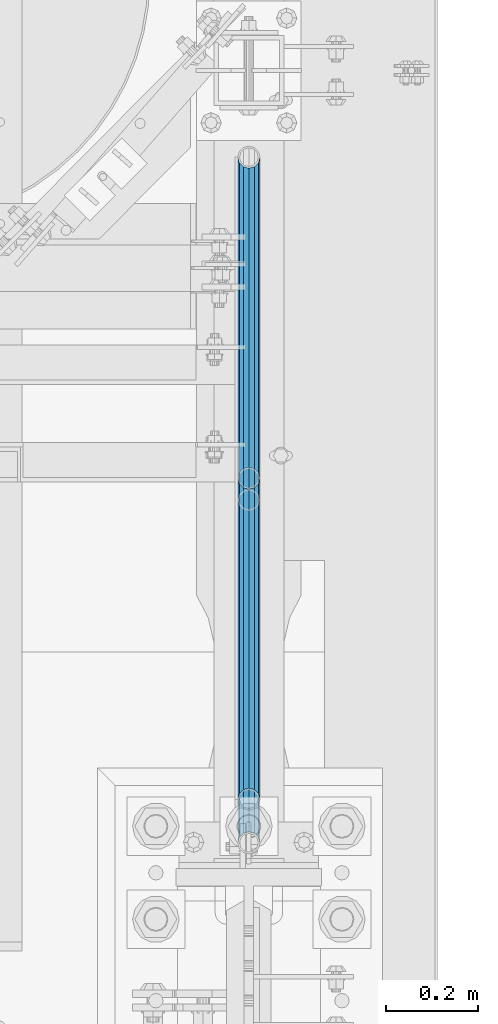
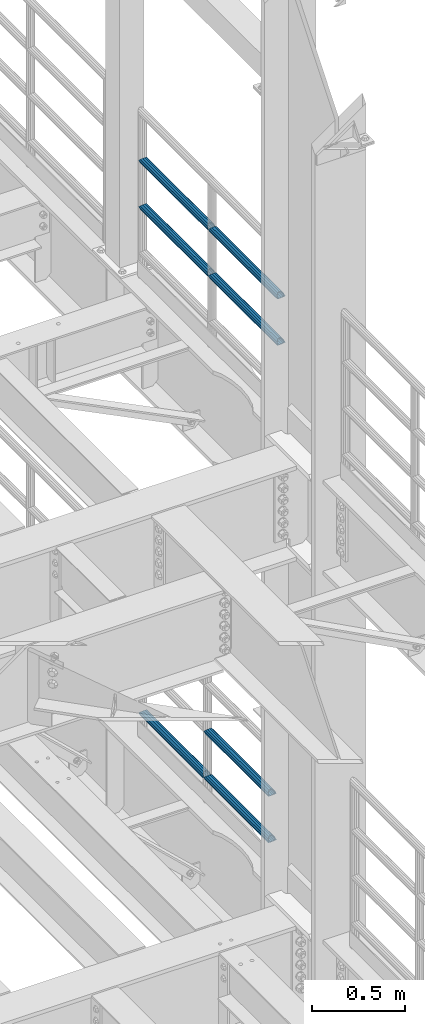
# One storey, part 1276 of 1876: 7 beams, 2 elements without a shape of their own.
"""IFC2X3 building model written with IfcOpenShell, lengths in millimetres."""

import ifcopenshell
import ifcopenshell.guid

model = None  # the IFC model being written
_history = None  # IfcOwnerHistory: only IFC2X3 demands one
_inside = {}  # id of a spatial element -> (the spatial element, [elements in it])
_under = {}  # id of a project, library or spatial element -> (it, [spatial elements below it])
_declared = {}  # id of a project -> (the project, [libraries it declares])
_typed = {}  # id of a type object -> (the type object, [elements of that type])
_made_of = {}  # id of a material, layer set ... -> (it, [elements and type objects made of it])


def new_model(schema):
    """Start an empty IFC model of exactly this schema.

    Asked for "IFC4X3", IfcOpenShell would pick the latest addendum, in which some entities
    have other attributes; the version numbers below select the first issue.
    IFC2X3 requires an IfcOwnerHistory on every rooted entity: one is made here for all.
    """
    global model, _history
    if schema == "IFC4X3":
        model = ifcopenshell.file(schema_version=(4, 3, 0, 0))
    else:
        model = ifcopenshell.file(schema=schema)
    _inside.clear()
    _under.clear()
    _declared.clear()
    _typed.clear()
    _made_of.clear()
    _history = None
    if model.schema == "IFC2X3":
        org = make("IfcOrganization", Name="unknown")
        user = make(
            "IfcPersonAndOrganization",
            ThePerson=make("IfcPerson", FamilyName="unknown"),
            TheOrganization=org,
        )
        app = make(
            "IfcApplication",
            ApplicationDeveloper=org,
            Version="unknown",
            ApplicationFullName="unknown",
            ApplicationIdentifier="unknown",
        )
        _history = make(
            "IfcOwnerHistory",
            OwningUser=user,
            OwningApplication=app,
            ChangeAction="ADDED",
            CreationDate=0,
        )
    return model


def make(cls, **values):
    """One entity of the class cls with the attributes given. An attribute that is None is left unset."""
    return model.create_entity(
        cls, **{name: value for name, value in values.items() if value is not None}
    )


def rooted(cls, **values):
    """An entity with a GlobalId (a new one), such as an element, a storey or a relation."""
    return make(cls, GlobalId=ifcopenshell.guid.new(), OwnerHistory=_history, **values)


def si_unit(unit_type, name, prefix=None):
    """IfcSIUnit, for example si_unit("LENGTHUNIT", "METRE", prefix="MILLI")."""
    return make("IfcSIUnit", UnitType=unit_type, Prefix=prefix, Name=name)


def assignment(units):
    """IfcUnitAssignment: the units of a project."""
    return None if units is None else make("IfcUnitAssignment", Units=units)


def point(xyz):
    """IfcCartesianPoint."""
    return None if xyz is None else make("IfcCartesianPoint", Coordinates=xyz)


def direction(xyz):
    """IfcDirection."""
    return None if xyz is None else make("IfcDirection", DirectionRatios=xyz)


def frame(location, z_axis=None, x_axis=None):
    """IfcAxis2Placement3D, a coordinate frame: its origin and axes. An axis left out is left unset."""
    return make(
        "IfcAxis2Placement3D",
        Location=point(location),
        Axis=direction(z_axis),
        RefDirection=direction(x_axis),
    )


def origin_with_axes():
    """The frame at (0, 0, 0) with the z axis (0, 0, 1) and the x axis (1, 0, 0) written out."""
    return frame((0.0, 0.0, 0.0), z_axis=(0.0, 0.0, 1.0), x_axis=(1.0, 0.0, 0.0))


def place(relative_to, where):
    """IfcLocalPlacement: puts the frame where relative to a parent placement (None: the world)."""
    return make(
        "IfcLocalPlacement", PlacementRelTo=relative_to, RelativePlacement=where
    )


def context(
    kind, dimensions, precision=None, world=None, true_north=None, identifier=None
):
    """IfcGeometricRepresentationContext, for example the 3D "Model" context."""
    return make(
        "IfcGeometricRepresentationContext",
        ContextIdentifier=identifier,
        ContextType=kind,
        CoordinateSpaceDimension=dimensions,
        Precision=precision,
        WorldCoordinateSystem=world,
        TrueNorth=true_north,
    )


def subcontext(parent, identifier, kind, view, scale=None):
    """IfcGeometricRepresentationSubContext, for example "Body" below "Model"."""
    return make(
        "IfcGeometricRepresentationSubContext",
        ContextIdentifier=identifier,
        ContextType=kind,
        ParentContext=parent,
        TargetScale=scale,
        TargetView=view,
    )


def project(units=None, contexts=None):
    """IfcProject with its units and contexts."""
    return rooted(
        "IfcProject",
        Name="project",
        RepresentationContexts=contexts,
        UnitsInContext=assignment(units),
    )


def spatial(cls, under=None, at=None, **own):
    """A site, building, storey or space (cls), placed at a placement, below another one or the project."""
    s = rooted(cls, ObjectPlacement=at, **own)
    if under is not None:
        _under.setdefault(under.id(), (under, []))[1].append(s)
    return s


def faces_of(points, faces, orient=None, outer=None):
    """IfcFace entities. A face is a list of loops; a loop is a list of indices into points, from 0.

    orient and outer hold one flag for each loop. By default every Orientation is true, the
    first loop of a face is its IfcFaceOuterBound and the others are IfcFaceBound.
    """
    made = []
    for i, loops in enumerate(faces):
        bounds = []
        for j, loop in enumerate(loops):
            is_outer = j == 0 if outer is None else outer[i][j]
            bounds.append(
                make(
                    "IfcFaceOuterBound" if is_outer else "IfcFaceBound",
                    Bound=make("IfcPolyLoop", Polygon=[points[k] for k in loop]),
                    Orientation=True if orient is None else orient[i][j],
                )
            )
        made.append(make("IfcFace", Bounds=bounds))
    return made


def faceted_brep(points, faces, orient=None, outer=None, voids=None):
    """IfcFacetedBrep: a solid bounded by flat faces; with voids (closed shells), ...WithVoids."""
    shared = [point(p) for p in points]
    hull = make("IfcClosedShell", CfsFaces=faces_of(shared, faces, orient, outer))
    if voids is None:
        return make("IfcFacetedBrep", Outer=hull)
    return make(
        "IfcFacetedBrepWithVoids",
        Outer=hull,
        Voids=[
            make(cls, CfsFaces=faces_of(shared, fs, o, b)) for cls, fs, o, b in voids
        ],
    )


def shape(context_of_items, identifier, shape_type, items):
    """IfcShapeRepresentation: the items that make up one representation, for example the "Body"."""
    return make(
        "IfcShapeRepresentation",
        ContextOfItems=context_of_items,
        RepresentationIdentifier=identifier,
        RepresentationType=shape_type,
        Items=items,
    )


def material(Name=None, Category=None):
    """IfcMaterial."""
    return make("IfcMaterial", Name=Name, Category=Category)


def made_of(thing, what):
    """Note that an element or type object is made of a material, layer set ...; save() writes the relation."""
    if what is not None:
        _made_of.setdefault(what.id(), (what, []))[1].append(thing)
    return thing


def type_object(cls, material=None, **own):
    """A type object (cls), such as IfcWallType, which elements share."""
    return made_of(rooted(cls, **own), material)


def element(
    cls,
    number,
    at=None,
    inside=None,
    cuts=None,
    type_object=None,
    material=None,
    context=None,
    identifier="Body",
    shape_type=None,
    held_by="IfcProductDefinitionShape",
    body=None,
    shapes=None,
    **own,
):
    """One element of the class cls, such as IfcWall. Its Tag is "e" and its number.

    at: its placement. inside: the storey or other place that contains it. cuts: it is an
    opening in that element (IfcRelVoidsElement). A single representation is given by context,
    identifier, shape_type and body (its items); several are given by shapes. held_by: the class
    of the entity that holds the representations. save() writes the other relations.
    """
    e = rooted(cls, Tag="e%d" % number, ObjectPlacement=at, **own)
    if body is not None:
        shapes = [shape(context, identifier, shape_type, body)]
    if shapes is not None:
        e.Representation = make(held_by, Representations=shapes)
    if inside is not None:
        _inside.setdefault(inside.id(), (inside, []))[1].append(e)
    if cuts is not None:
        rooted(
            "IfcRelVoidsElement", RelatingBuildingElement=cuts, RelatedOpeningElement=e
        )
    if type_object is not None:
        _typed.setdefault(type_object.id(), (type_object, []))[1].append(e)
    return made_of(e, material)


def aggregate(whole, parts):
    """IfcRelAggregates: a whole, such as a stair, and the parts it consists of."""
    return rooted("IfcRelAggregates", RelatingObject=whole, RelatedObjects=parts)


def save(model, path):
    """Write the relations noted so far, then the file.

    IfcRelAggregates (storeys below a building ...), IfcRelContainedInSpatialStructure (elements
    in a storey), IfcRelDefinesByType, IfcRelAssociatesMaterial and IfcRelDeclares: one each for
    every whole, place, type object, material and project.
    """
    for whole, parts in _under.values():
        aggregate(whole, parts)
    for where, things in _inside.values():
        rooted(
            "IfcRelContainedInSpatialStructure",
            RelatedElements=things,
            RelatingStructure=where,
        )
    for kind, things in _typed.values():
        rooted("IfcRelDefinesByType", RelatedObjects=things, RelatingType=kind)
    for what, things in _made_of.values():
        rooted("IfcRelAssociatesMaterial", RelatedObjects=things, RelatingMaterial=what)
    for by, libraries in _declared.values():
        rooted("IfcRelDeclares", RelatingContext=by, RelatedDefinitions=libraries)
    model.write(path)


model = new_model("IFC2X3")

# Units and contexts
model_context = context("Model", 3, precision=1e-05, world=origin_with_axes())
body_context = subcontext(model_context, "Body", "Model", "MODEL_VIEW")
ifc_project = project(units=[si_unit("LENGTHUNIT", "METRE", prefix="MILLI"), si_unit("AREAUNIT", "SQUARE_METRE"), si_unit("VOLUMEUNIT", "CUBIC_METRE"), si_unit("MASSUNIT", "GRAM", prefix="KILO"), si_unit("TIMEUNIT", "SECOND"), si_unit("PLANEANGLEUNIT", "RADIAN"), si_unit("SOLIDANGLEUNIT", "STERADIAN"), si_unit("THERMODYNAMICTEMPERATUREUNIT", "DEGREE_CELSIUS"), si_unit("LUMINOUSINTENSITYUNIT", "LUMEN")], contexts=[model_context])

# Site, building, storey
site_placement = place(None, origin_with_axes())
site = spatial("IfcSite", under=ifc_project, at=site_placement, CompositionType="ELEMENT")
building_placement = place(site_placement, origin_with_axes())
building = spatial("IfcBuilding", under=site, at=building_placement, Name="Undefined", CompositionType="ELEMENT")
storey_placement = place(building_placement, origin_with_axes())
storey = spatial("IfcBuildingStorey", under=building, at=storey_placement, Name="Undefined", CompositionType="ELEMENT", Elevation=0.0)

# Assembly, beams
assembly_1_placement = place(storey_placement, origin_with_axes())
assembly_1 = element("IfcElementAssembly", 1, at=assembly_1_placement, inside=storey, Name="RAIL", AssemblyPlace="NOTDEFINED", PredefinedType="RIGID_FRAME")
ifc_material = material()
beam_type = type_object("IfcBeamType", Name="PIPE1-1/2SCH40", PredefinedType="NOTDEFINED")
beam_1_placement = place(assembly_1_placement, frame((7620.0, 1868.805, 8620.125), z_axis=(0.0, 0.0, -1.0), x_axis=(0.0, 1.0, 0.0)))
beam_1 = element("IfcBeam", 2, at=beam_1_placement, type_object=beam_type, material=ifc_material, Name="RAIL", ObjectType="PIPE1-1/2SCH40", context=body_context, shape_type="Brep", body=[
    faceted_brep([(0.0, 24.1299999999992, 0.0), (12.0650000000064, 20.8971929933177, -12.0649999999987), (12.0650000000064, 20.8971929933177, 12.0649999999987), (12.0650000000064, -20.8971929933177, 12.0649999999987), (12.0650000000064, -20.8971929933177, -12.0649999999987), (0.0, -24.1299999999992, 0.0), (20.8971929933249, -12.0650000000005, 20.8971929933177), (20.8971929933249, -12.0650000000005, 15.8661214311796), (15.2545715621445, -17.7076214311801, 10.2235000000001), (12.5151929933249, -20.4470000000001, 0.0), (15.2545715621445, -17.7076214311801, -10.2235000000001), (20.8971929933249, -12.0650000000005, -15.8661214311796), (20.8971929933249, -12.0650000000005, -20.8971929933177), (24.1300000000063, 0.0, -20.4470000000001), (24.1300000000063, 0.0, -24.130000000001), (21.3906214311868, -10.2235000000001, -17.7076214311819), (21.3906214311868, 10.2235000000001, -17.7076214311819), (20.8971929933249, 12.0650000000005, -15.8661214311796), (20.8971929933249, 12.0650000000005, -20.8971929933177), (15.2545715621445, 17.7076214311801, -10.2235000000001), (12.5151929933249, 20.4470000000001, 0.0), (15.2545715621445, 17.7076214311801, 10.2235000000001), (20.8971929933249, 12.0650000000005, 15.8661214311796), (20.8971929933249, 12.0650000000005, 20.8971929933177), (21.3906214311868, 10.2235000000001, 17.7076214311819), (24.1300000000064, 0.0, 20.4470000000001), (24.1300000000064, 0.0, 24.130000000001), (21.3906214311868, -10.2235000000001, 17.7076214311819), (748.982500000002, 24.1300000000001, 0.0), (736.917500000002, 20.8971929933186, -12.0649999999987), (728.085307006683, 12.0649999999996, -20.8971929933177), (748.982500000002, -24.1300000000001, 0.0), (736.917500000002, -20.8971929933186, -12.0649999999987), (736.917500000002, -20.8971929933186, 12.0649999999987), (728.085307006683, -12.0649999999996, 20.8971929933177), (728.085307006683, -12.0649999999996, -20.8971929933177), (724.852500000002, 0.0, -24.130000000001), (727.591878568821, 10.2235000000001, -17.7076214311819), (724.852500000002, 0.0, -20.4470000000001), (728.085307006683, 12.0649999999996, -15.8661214311796), (728.085307006683, -12.0649999999996, -15.8661214311796), (727.591878568821, -10.2235000000001, -17.7076214311819), (733.727928437864, -17.7076214311801, -10.2235000000001), (736.467307006683, -20.4470000000001, 0.0), (733.727928437864, -17.7076214311801, 10.2235000000001), (728.085307006683, -12.0649999999996, 15.8661214311796), (727.591878568821, -10.2235000000001, 17.7076214311819), (724.852500000002, 0.0, 20.4470000000001), (724.852500000002, 0.0, 24.130000000001), (728.085307006683, 12.0649999999996, 20.8971929933177), (736.917500000002, 20.8971929933186, 12.0649999999987), (728.085307006683, 12.0649999999996, 15.8661214311796), (733.727928437864, 17.7076214311801, 10.2235000000001), (736.467307006683, 20.4470000000001, 0.0), (733.727928437864, 17.7076214311801, -10.2235000000001), (727.591878568821, 10.2235000000001, 17.7076214311819)], [[[0, 1, 2]], [[3, 4, 5]], [[6, 7, 8, 9, 10, 11, 12, 4, 3]], [[13, 14, 12, 11, 15]], [[16, 17, 18, 14, 13]], [[2, 1, 18, 17, 19, 20, 21, 22, 23]], [[23, 22, 24, 25, 26]], [[26, 25, 27, 7, 6]], [[1, 0, 28, 29]], [[18, 1, 29, 30]], [[31, 32, 33]], [[6, 3, 33, 34]], [[3, 5, 31, 33]], [[5, 4, 32, 31]], [[4, 12, 35, 32]], [[12, 14, 36, 35]], [[14, 18, 30, 36]], [[37, 38, 36, 30, 39]], [[40, 35, 36, 38, 41]], [[33, 32, 35, 40, 42, 43, 44, 45, 34]], [[34, 45, 46, 47, 48]], [[26, 6, 34, 48]], [[2, 23, 49, 50]], [[23, 26, 48, 49]], [[0, 2, 50, 28]], [[28, 50, 29]], [[49, 51, 52, 53, 54, 39, 30, 29, 50]], [[48, 47, 55, 51, 49]], [[25, 24, 55, 47]], [[55, 24, 22, 21, 52, 51]], [[21, 20, 53, 52]], [[20, 19, 54, 53]], [[19, 17, 16, 37, 39, 54]], [[16, 13, 38, 37]], [[13, 15, 41, 38]], [[41, 15, 11, 10, 42, 40]], [[10, 9, 43, 42]], [[9, 8, 44, 43]], [[8, 7, 27, 46, 45, 44]], [[27, 25, 47, 46]]]),
])
beam_2_placement = place(assembly_1_placement, frame((7620.0, 2617.7875, 8620.125), z_axis=(0.0, 0.0, -1.0), x_axis=(0.0, 1.0, 0.0)))
beam_2 = element("IfcBeam", 3, at=beam_2_placement, type_object=beam_type, material=ifc_material, Name="RAIL", ObjectType="PIPE1-1/2SCH40", context=body_context, shape_type="Brep", body=[
    faceted_brep([(0.0, 24.1299999999992, 0.0), (12.0650000000064, 20.8971929933177, -12.0649999999987), (12.0650000000064, 20.8971929933177, 12.0649999999987), (12.0650000000064, -20.8971929933177, 12.0649999999987), (12.0650000000064, -20.8971929933177, -12.0649999999987), (0.0, -24.1299999999992, 0.0), (20.8971929933249, -12.0650000000005, 20.8971929933177), (20.8971929933249, -12.0650000000005, 15.8661214311796), (15.2545715621445, -17.7076214311801, 10.2235000000001), (12.5151929933249, -20.4470000000001, 0.0), (15.2545715621445, -17.7076214311801, -10.2235000000001), (20.8971929933249, -12.0650000000005, -15.8661214311796), (20.8971929933249, -12.0650000000005, -20.8971929933177), (24.1300000000063, 0.0, -20.4470000000001), (24.1300000000063, 0.0, -24.130000000001), (21.3906214311868, -10.2235000000001, -17.7076214311819), (21.3906214311868, 10.2235000000001, -17.7076214311819), (20.8971929933249, 12.0650000000005, -15.8661214311796), (20.8971929933249, 12.0650000000005, -20.8971929933177), (15.2545715621445, 17.7076214311801, -10.2235000000001), (12.5151929933249, 20.4470000000001, 0.0), (15.2545715621445, 17.7076214311801, 10.2235000000001), (20.8971929933249, 12.0650000000005, 15.8661214311796), (20.8971929933249, 12.0650000000005, 20.8971929933177), (21.3906214311868, 10.2235000000001, 17.7076214311819), (24.1300000000064, 0.0, 20.4470000000001), (24.1300000000064, 0.0, 24.130000000001), (21.3906214311868, -10.2235000000001, 17.7076214311819), (748.982500000002, 24.1300000000001, 0.0), (736.917500000002, 20.8971929933186, -12.0649999999987), (728.085307006683, 12.0649999999996, -20.8971929933177), (748.982500000002, -24.1300000000001, 0.0), (736.917500000002, -20.8971929933186, -12.0649999999987), (736.917500000002, -20.8971929933186, 12.0649999999987), (728.085307006683, -12.0649999999996, 20.8971929933177), (728.085307006683, -12.0649999999996, -20.8971929933177), (724.852500000002, 0.0, -24.130000000001), (727.591878568821, 10.2235000000001, -17.7076214311819), (724.852500000002, 0.0, -20.4470000000001), (728.085307006683, 12.0649999999996, -15.8661214311796), (728.085307006683, -12.0649999999996, -15.8661214311796), (727.591878568821, -10.2235000000001, -17.7076214311819), (733.727928437864, -17.7076214311801, -10.2235000000001), (736.467307006683, -20.4470000000001, 0.0), (733.727928437864, -17.7076214311801, 10.2235000000001), (728.085307006683, -12.0649999999996, 15.8661214311796), (727.591878568821, -10.2235000000001, 17.7076214311819), (724.852500000002, 0.0, 20.4470000000001), (724.852500000002, 0.0, 24.130000000001), (728.085307006683, 12.0649999999996, 20.8971929933177), (736.917500000002, 20.8971929933186, 12.0649999999987), (728.085307006683, 12.0649999999996, 15.8661214311796), (733.727928437864, 17.7076214311801, 10.2235000000001), (736.467307006683, 20.4470000000001, 0.0), (733.727928437864, 17.7076214311801, -10.2235000000001), (727.591878568821, 10.2235000000001, 17.7076214311819)], [[[0, 1, 2]], [[3, 4, 5]], [[6, 7, 8, 9, 10, 11, 12, 4, 3]], [[13, 14, 12, 11, 15]], [[16, 17, 18, 14, 13]], [[2, 1, 18, 17, 19, 20, 21, 22, 23]], [[23, 22, 24, 25, 26]], [[26, 25, 27, 7, 6]], [[1, 0, 28, 29]], [[18, 1, 29, 30]], [[31, 32, 33]], [[6, 3, 33, 34]], [[3, 5, 31, 33]], [[5, 4, 32, 31]], [[4, 12, 35, 32]], [[12, 14, 36, 35]], [[14, 18, 30, 36]], [[37, 38, 36, 30, 39]], [[40, 35, 36, 38, 41]], [[33, 32, 35, 40, 42, 43, 44, 45, 34]], [[34, 45, 46, 47, 48]], [[26, 6, 34, 48]], [[2, 23, 49, 50]], [[23, 26, 48, 49]], [[0, 2, 50, 28]], [[28, 50, 29]], [[49, 51, 52, 53, 54, 39, 30, 29, 50]], [[48, 47, 55, 51, 49]], [[25, 24, 55, 47]], [[55, 24, 22, 21, 52, 51]], [[21, 20, 53, 52]], [[20, 19, 54, 53]], [[19, 17, 16, 37, 39, 54]], [[16, 13, 38, 37]], [[13, 15, 41, 38]], [[41, 15, 11, 10, 42, 40]], [[10, 9, 43, 42]], [[9, 8, 44, 43]], [[8, 7, 27, 46, 45, 44]], [[27, 25, 47, 46]]]),
])
beam_3_placement = place(assembly_1_placement, frame((7620.0, 1868.805, 8924.925), z_axis=(0.0, 0.0, -1.0), x_axis=(0.0, 1.0, 0.0)))
beam_3 = element("IfcBeam", 4, at=beam_3_placement, type_object=beam_type, material=ifc_material, Name="RAIL", ObjectType="PIPE1-1/2SCH40", context=body_context, shape_type="Brep", body=[
    faceted_brep([(0.0, 24.1299999999992, 0.0), (12.0650000000064, 20.8971929933177, -12.0649999999987), (12.0650000000064, 20.8971929933177, 12.0649999999987), (12.0650000000064, -20.8971929933177, 12.0649999999987), (12.0650000000064, -20.8971929933177, -12.0649999999987), (0.0, -24.1299999999992, 0.0), (20.8971929933249, -12.0650000000005, 20.8971929933177), (20.8971929933249, -12.0650000000005, 15.8661214311796), (15.2545715621445, -17.7076214311801, 10.2235000000001), (12.5151929933249, -20.4470000000001, 0.0), (15.2545715621445, -17.7076214311801, -10.2235000000001), (20.8971929933249, -12.0650000000005, -15.8661214311796), (20.8971929933249, -12.0650000000005, -20.8971929933177), (24.1300000000063, 0.0, -20.4470000000001), (24.1300000000063, 0.0, -24.130000000001), (21.3906214311868, -10.2235000000001, -17.7076214311819), (21.3906214311868, 10.2235000000001, -17.7076214311819), (20.8971929933249, 12.0650000000005, -15.8661214311796), (20.8971929933249, 12.0650000000005, -20.8971929933177), (15.2545715621445, 17.7076214311801, -10.2235000000001), (12.5151929933249, 20.4470000000001, 0.0), (15.2545715621445, 17.7076214311801, 10.2235000000001), (20.8971929933249, 12.0650000000005, 15.8661214311796), (20.8971929933249, 12.0650000000005, 20.8971929933177), (21.3906214311868, 10.2235000000001, 17.7076214311819), (24.1300000000064, 0.0, 20.4470000000001), (24.1300000000064, 0.0, 24.130000000001), (21.3906214311868, -10.2235000000001, 17.7076214311819), (748.982500000002, 24.1300000000001, 0.0), (736.917500000002, 20.8971929933186, -12.0649999999987), (728.085307006683, 12.0649999999996, -20.8971929933177), (748.982500000002, -24.1300000000001, 0.0), (736.917500000002, -20.8971929933186, -12.0649999999987), (736.917500000002, -20.8971929933186, 12.0649999999987), (728.085307006683, -12.0649999999996, 20.8971929933177), (728.085307006683, -12.0649999999996, -20.8971929933177), (724.852500000002, 0.0, -24.130000000001), (727.591878568821, 10.2235000000001, -17.7076214311819), (724.852500000002, 0.0, -20.4470000000001), (728.085307006683, 12.0649999999996, -15.8661214311796), (728.085307006683, -12.0649999999996, -15.8661214311796), (727.591878568821, -10.2235000000001, -17.7076214311819), (733.727928437864, -17.7076214311801, -10.2235000000001), (736.467307006683, -20.4470000000001, 0.0), (733.727928437864, -17.7076214311801, 10.2235000000001), (728.085307006683, -12.0649999999996, 15.8661214311796), (727.591878568821, -10.2235000000001, 17.7076214311819), (724.852500000002, 0.0, 20.4470000000001), (724.852500000002, 0.0, 24.130000000001), (728.085307006683, 12.0649999999996, 20.8971929933177), (736.917500000002, 20.8971929933186, 12.0649999999987), (728.085307006683, 12.0649999999996, 15.8661214311796), (733.727928437864, 17.7076214311801, 10.2235000000001), (736.467307006683, 20.4470000000001, 0.0), (733.727928437864, 17.7076214311801, -10.2235000000001), (727.591878568821, 10.2235000000001, 17.7076214311819)], [[[0, 1, 2]], [[3, 4, 5]], [[6, 7, 8, 9, 10, 11, 12, 4, 3]], [[13, 14, 12, 11, 15]], [[16, 17, 18, 14, 13]], [[2, 1, 18, 17, 19, 20, 21, 22, 23]], [[23, 22, 24, 25, 26]], [[26, 25, 27, 7, 6]], [[1, 0, 28, 29]], [[18, 1, 29, 30]], [[31, 32, 33]], [[6, 3, 33, 34]], [[3, 5, 31, 33]], [[5, 4, 32, 31]], [[4, 12, 35, 32]], [[12, 14, 36, 35]], [[14, 18, 30, 36]], [[37, 38, 36, 30, 39]], [[40, 35, 36, 38, 41]], [[33, 32, 35, 40, 42, 43, 44, 45, 34]], [[34, 45, 46, 47, 48]], [[26, 6, 34, 48]], [[2, 23, 49, 50]], [[23, 26, 48, 49]], [[0, 2, 50, 28]], [[28, 50, 29]], [[49, 51, 52, 53, 54, 39, 30, 29, 50]], [[48, 47, 55, 51, 49]], [[25, 24, 55, 47]], [[55, 24, 22, 21, 52, 51]], [[21, 20, 53, 52]], [[20, 19, 54, 53]], [[19, 17, 16, 37, 39, 54]], [[16, 13, 38, 37]], [[13, 15, 41, 38]], [[41, 15, 11, 10, 42, 40]], [[10, 9, 43, 42]], [[9, 8, 44, 43]], [[8, 7, 27, 46, 45, 44]], [[27, 25, 47, 46]]]),
])
beam_4_placement = place(assembly_1_placement, frame((7620.0, 2617.7875, 8924.925), z_axis=(0.0, 0.0, -1.0), x_axis=(0.0, 1.0, 0.0)))
beam_4 = element("IfcBeam", 5, at=beam_4_placement, type_object=beam_type, material=ifc_material, Name="RAIL", ObjectType="PIPE1-1/2SCH40", context=body_context, shape_type="Brep", body=[
    faceted_brep([(0.0, 24.1299999999992, 0.0), (12.0650000000064, 20.8971929933177, -12.0649999999987), (12.0650000000064, 20.8971929933177, 12.0649999999987), (12.0650000000064, -20.8971929933177, 12.0649999999987), (12.0650000000064, -20.8971929933177, -12.0649999999987), (0.0, -24.1299999999992, 0.0), (20.8971929933249, -12.0650000000005, 20.8971929933177), (20.8971929933249, -12.0650000000005, 15.8661214311796), (15.2545715621445, -17.7076214311801, 10.2235000000001), (12.5151929933249, -20.4470000000001, 0.0), (15.2545715621445, -17.7076214311801, -10.2235000000001), (20.8971929933249, -12.0650000000005, -15.8661214311796), (20.8971929933249, -12.0650000000005, -20.8971929933177), (24.1300000000063, 0.0, -20.4470000000001), (24.1300000000063, 0.0, -24.130000000001), (21.3906214311868, -10.2235000000001, -17.7076214311819), (21.3906214311868, 10.2235000000001, -17.7076214311819), (20.8971929933249, 12.0650000000005, -15.8661214311796), (20.8971929933249, 12.0650000000005, -20.8971929933177), (15.2545715621445, 17.7076214311801, -10.2235000000001), (12.5151929933249, 20.4470000000001, 0.0), (15.2545715621445, 17.7076214311801, 10.2235000000001), (20.8971929933249, 12.0650000000005, 15.8661214311796), (20.8971929933249, 12.0650000000005, 20.8971929933177), (21.3906214311868, 10.2235000000001, 17.7076214311819), (24.1300000000064, 0.0, 20.4470000000001), (24.1300000000064, 0.0, 24.130000000001), (21.3906214311868, -10.2235000000001, 17.7076214311819), (748.982500000002, 24.1300000000001, 0.0), (736.917500000002, 20.8971929933186, -12.0649999999987), (728.085307006683, 12.0649999999996, -20.8971929933177), (748.982500000002, -24.1300000000001, 0.0), (736.917500000002, -20.8971929933186, -12.0649999999987), (736.917500000002, -20.8971929933186, 12.0649999999987), (728.085307006683, -12.0649999999996, 20.8971929933177), (728.085307006683, -12.0649999999996, -20.8971929933177), (724.852500000002, 0.0, -24.130000000001), (727.591878568821, 10.2235000000001, -17.7076214311819), (724.852500000002, 0.0, -20.4470000000001), (728.085307006683, 12.0649999999996, -15.8661214311796), (728.085307006683, -12.0649999999996, -15.8661214311796), (727.591878568821, -10.2235000000001, -17.7076214311819), (733.727928437864, -17.7076214311801, -10.2235000000001), (736.467307006683, -20.4470000000001, 0.0), (733.727928437864, -17.7076214311801, 10.2235000000001), (728.085307006683, -12.0649999999996, 15.8661214311796), (727.591878568821, -10.2235000000001, 17.7076214311819), (724.852500000002, 0.0, 20.4470000000001), (724.852500000002, 0.0, 24.130000000001), (728.085307006683, 12.0649999999996, 20.8971929933177), (736.917500000002, 20.8971929933186, 12.0649999999987), (728.085307006683, 12.0649999999996, 15.8661214311796), (733.727928437864, 17.7076214311801, 10.2235000000001), (736.467307006683, 20.4470000000001, 0.0), (733.727928437864, 17.7076214311801, -10.2235000000001), (727.591878568821, 10.2235000000001, 17.7076214311819)], [[[0, 1, 2]], [[3, 4, 5]], [[6, 7, 8, 9, 10, 11, 12, 4, 3]], [[13, 14, 12, 11, 15]], [[16, 17, 18, 14, 13]], [[2, 1, 18, 17, 19, 20, 21, 22, 23]], [[23, 22, 24, 25, 26]], [[26, 25, 27, 7, 6]], [[1, 0, 28, 29]], [[18, 1, 29, 30]], [[31, 32, 33]], [[6, 3, 33, 34]], [[3, 5, 31, 33]], [[5, 4, 32, 31]], [[4, 12, 35, 32]], [[12, 14, 36, 35]], [[14, 18, 30, 36]], [[37, 38, 36, 30, 39]], [[40, 35, 36, 38, 41]], [[33, 32, 35, 40, 42, 43, 44, 45, 34]], [[34, 45, 46, 47, 48]], [[26, 6, 34, 48]], [[2, 23, 49, 50]], [[23, 26, 48, 49]], [[0, 2, 50, 28]], [[28, 50, 29]], [[49, 51, 52, 53, 54, 39, 30, 29, 50]], [[48, 47, 55, 51, 49]], [[25, 24, 55, 47]], [[55, 24, 22, 21, 52, 51]], [[21, 20, 53, 52]], [[20, 19, 54, 53]], [[19, 17, 16, 37, 39, 54]], [[16, 13, 38, 37]], [[13, 15, 41, 38]], [[41, 15, 11, 10, 42, 40]], [[10, 9, 43, 42]], [[9, 8, 44, 43]], [[8, 7, 27, 46, 45, 44]], [[27, 25, 47, 46]]]),
])
aggregate(assembly_1, [beam_1, beam_2, beam_3, beam_4])

assembly_2_placement = place(storey_placement, origin_with_axes())
assembly_2 = element("IfcElementAssembly", 6, at=assembly_2_placement, inside=storey, Name="RAIL", AssemblyPlace="NOTDEFINED", PredefinedType="RIGID_FRAME")
beam_5_placement = place(assembly_2_placement, frame((7620.0, 2665.4125, 5292.725), z_axis=(0.0, 0.0, 1.0), x_axis=(0.0, -1.0, 0.0)))
beam_5 = element("IfcBeam", 7, at=beam_5_placement, type_object=beam_type, material=ifc_material, Name="RAIL", ObjectType="PIPE1-1/2SCH40", context=body_context, shape_type="Brep", body=[
    faceted_brep([(680.460307006681, -12.0649999999996, 20.8971929933186), (680.460307006681, -12.0649999999914, 15.8661214311887), (679.966878568822, -10.2235000000001, 17.7076214311801), (677.2275, 0.0, 20.4470000000001), (677.2275, 0.0, 24.1300000000001), (679.966878568817, 10.2235000000001, 17.7076214311801), (680.460307006681, 12.0650000000078, 15.8661214311724), (680.460307006681, 12.0649999999996, 20.8971929933186), (701.3575, 24.1300000000001, 0.0), (689.2925, 20.8971929933186, 12.0649999999996), (689.2925, 20.8971929933186, -12.0649999999996), (686.102928437854, 17.7076214311801, 10.2235000000001), (688.842307006673, 20.4470000000001, 0.0), (686.102928437854, 17.7076214311801, -10.2235000000001), (680.460307006681, 12.0650000000078, -15.8661214311724), (680.460307006681, 12.0649999999996, -20.8971929933186), (679.966878568817, 10.2235000000001, -17.7076214311801), (677.2275, 0.0, -20.4470000000001), (677.2275, 0.0, -24.1300000000001), (680.460307006681, -12.0649999999914, -15.8661214311887), (680.460307006681, -12.0649999999996, -20.8971929933186), (679.966878568822, -10.2235000000001, -17.7076214311801), (701.3575, -24.1299999999919, 0.0), (689.2925, -20.8971929933186, -12.0649999999996), (689.2925, -20.8971929933186, 12.0649999999996), (686.10292843787, -17.7076214311801, -10.2235000000001), (688.842307006689, -20.4470000000001, 0.0), (686.10292843787, -17.7076214311801, 10.2235000000001), (12.0650000000064, -20.8971929933177, -12.0649999999987), (20.8971929933249, -12.0650000000005, -20.8971929933177), (0.0, 24.1299999999992, 0.0), (12.0650000000064, 20.8971929933177, -12.0649999999987), (12.0650000000064, 20.8971929933177, 12.0649999999987), (20.8971929933249, 12.0650000000005, 20.8971929933177), (24.1300000000064, 0.0, 24.130000000001), (20.8971929933249, 12.0650000000005, -20.8971929933177), (24.1300000000063, 0.0, -24.130000000001), (24.1300000000063, 0.0, -20.4470000000001), (20.8971929933249, -12.0650000000005, -15.8661214311796), (21.3906214311868, -10.2235000000001, -17.7076214311819), (21.3906214311868, 10.2235000000001, -17.7076214311819), (20.8971929933249, 12.0650000000005, -15.8661214311796), (15.2545715621445, 17.7076214311801, -10.2235000000001), (12.5151929933249, 20.4470000000001, 0.0), (15.2545715621445, 17.7076214311801, 10.2235000000001), (20.8971929933249, 12.0650000000005, 15.8661214311796), (21.3906214311868, 10.2235000000001, 17.7076214311819), (24.1300000000064, 0.0, 20.4470000000001), (21.3906214311868, -10.2235000000001, 17.7076214311819), (20.8971929933249, -12.0650000000005, 15.8661214311796), (20.8971929933249, -12.0650000000005, 20.8971929933177), (12.0650000000064, -20.8971929933177, 12.0649999999987), (0.0, -24.1299999999992, 0.0), (15.2545715621445, -17.7076214311801, 10.2235000000001), (12.5151929933249, -20.4470000000001, 0.0), (15.2545715621445, -17.7076214311801, -10.2235000000001)], [[[0, 1, 2, 3, 4]], [[4, 3, 5, 6, 7]], [[8, 9, 10]], [[7, 6, 11, 12, 13, 14, 15, 10, 9]], [[16, 17, 18, 15, 14]], [[19, 20, 18, 17, 21]], [[22, 23, 24]], [[24, 23, 20, 19, 25, 26, 27, 1, 0]], [[28, 29, 20, 23]], [[30, 31, 32]], [[33, 34, 4, 7]], [[32, 33, 7, 9]], [[30, 32, 9, 8]], [[31, 30, 8, 10]], [[35, 31, 10, 15]], [[36, 35, 15, 18]], [[29, 36, 18, 20]], [[37, 36, 29, 38, 39]], [[40, 41, 35, 36, 37]], [[32, 31, 35, 41, 42, 43, 44, 45, 33]], [[33, 45, 46, 47, 34]], [[34, 47, 48, 49, 50]], [[34, 50, 0, 4]], [[50, 51, 24, 0]], [[51, 52, 22, 24]], [[52, 28, 23, 22]], [[51, 28, 52]], [[50, 49, 53, 54, 55, 38, 29, 28, 51]], [[55, 54, 26, 25]], [[21, 39, 38, 55, 25, 19]], [[37, 39, 21, 17]], [[40, 37, 17, 16]], [[42, 41, 40, 16, 14, 13]], [[43, 42, 13, 12]], [[44, 43, 12, 11]], [[5, 46, 45, 44, 11, 6]], [[47, 46, 5, 3]], [[48, 47, 3, 2]], [[53, 49, 48, 2, 1, 27]], [[54, 53, 27, 26]]]),
])
beam_6_placement = place(assembly_2_placement, frame((7619.99999999999, 3366.77, 5292.725), z_axis=(0.0, 0.0, 1.0), x_axis=(0.0, -1.0, 0.0)))
beam_6 = element("IfcBeam", 8, at=beam_6_placement, type_object=beam_type, material=ifc_material, Name="RAIL", ObjectType="PIPE1-1/2SCH40", context=body_context, shape_type="Brep", body=[
    faceted_brep([(680.460307006681, -12.0649999999996, 20.8971929933186), (680.460307006681, -12.0649999999914, 15.8661214311887), (679.966878568822, -10.2235000000001, 17.7076214311801), (677.2275, 0.0, 20.4470000000001), (677.2275, 0.0, 24.1300000000001), (679.966878568817, 10.2235000000001, 17.7076214311801), (680.460307006681, 12.0650000000078, 15.8661214311724), (680.460307006681, 12.0649999999996, 20.8971929933186), (701.3575, 24.1300000000001, 0.0), (689.2925, 20.8971929933186, 12.0649999999996), (689.2925, 20.8971929933186, -12.0649999999996), (686.102928437854, 17.7076214311801, 10.2235000000001), (688.842307006673, 20.4470000000001, 0.0), (686.102928437854, 17.7076214311801, -10.2235000000001), (680.460307006681, 12.0650000000078, -15.8661214311724), (680.460307006681, 12.0649999999996, -20.8971929933186), (679.966878568817, 10.2235000000001, -17.7076214311801), (677.2275, 0.0, -20.4470000000001), (677.2275, 0.0, -24.1300000000001), (680.460307006681, -12.0649999999914, -15.8661214311887), (680.460307006681, -12.0649999999996, -20.8971929933186), (679.966878568822, -10.2235000000001, -17.7076214311801), (701.3575, -24.1299999999919, 0.0), (689.2925, -20.8971929933186, -12.0649999999996), (689.2925, -20.8971929933186, 12.0649999999996), (686.10292843787, -17.7076214311801, -10.2235000000001), (688.842307006689, -20.4470000000001, 0.0), (686.10292843787, -17.7076214311801, 10.2235000000001), (12.0650000000064, -20.8971929933177, -12.0649999999987), (20.8971929933249, -12.0650000000005, -20.8971929933177), (0.0, 24.1299999999992, 0.0), (12.0650000000064, 20.8971929933177, -12.0649999999987), (12.0650000000064, 20.8971929933177, 12.0649999999987), (20.8971929933249, 12.0650000000005, 20.8971929933177), (24.1300000000064, 0.0, 24.130000000001), (20.8971929933249, 12.0650000000005, -20.8971929933177), (24.1300000000063, 0.0, -24.130000000001), (24.1300000000063, 0.0, -20.4470000000001), (20.8971929933249, -12.0650000000005, -15.8661214311796), (21.3906214311868, -10.2235000000001, -17.7076214311819), (21.3906214311868, 10.2235000000001, -17.7076214311819), (20.8971929933249, 12.0650000000005, -15.8661214311796), (15.2545715621445, 17.7076214311801, -10.2235000000001), (12.5151929933249, 20.4470000000001, 0.0), (15.2545715621445, 17.7076214311801, 10.2235000000001), (20.8971929933249, 12.0650000000005, 15.8661214311796), (21.3906214311868, 10.2235000000001, 17.7076214311819), (24.1300000000064, 0.0, 20.4470000000001), (21.3906214311868, -10.2235000000001, 17.7076214311819), (20.8971929933249, -12.0650000000005, 15.8661214311796), (20.8971929933249, -12.0650000000005, 20.8971929933177), (12.0650000000064, -20.8971929933177, 12.0649999999987), (0.0, -24.1299999999992, 0.0), (15.2545715621445, -17.7076214311801, 10.2235000000001), (12.5151929933249, -20.4470000000001, 0.0), (15.2545715621445, -17.7076214311801, -10.2235000000001)], [[[0, 1, 2, 3, 4]], [[4, 3, 5, 6, 7]], [[8, 9, 10]], [[7, 6, 11, 12, 13, 14, 15, 10, 9]], [[16, 17, 18, 15, 14]], [[19, 20, 18, 17, 21]], [[22, 23, 24]], [[24, 23, 20, 19, 25, 26, 27, 1, 0]], [[28, 29, 20, 23]], [[30, 31, 32]], [[33, 34, 4, 7]], [[32, 33, 7, 9]], [[30, 32, 9, 8]], [[31, 30, 8, 10]], [[35, 31, 10, 15]], [[36, 35, 15, 18]], [[29, 36, 18, 20]], [[37, 36, 29, 38, 39]], [[40, 41, 35, 36, 37]], [[32, 31, 35, 41, 42, 43, 44, 45, 33]], [[33, 45, 46, 47, 34]], [[34, 47, 48, 49, 50]], [[34, 50, 0, 4]], [[50, 51, 24, 0]], [[51, 52, 22, 24]], [[52, 28, 23, 22]], [[51, 28, 52]], [[50, 49, 53, 54, 55, 38, 29, 28, 51]], [[55, 54, 26, 25]], [[21, 39, 38, 55, 25, 19]], [[37, 39, 21, 17]], [[40, 37, 17, 16]], [[42, 41, 40, 16, 14, 13]], [[43, 42, 13, 12]], [[44, 43, 12, 11]], [[5, 46, 45, 44, 11, 6]], [[47, 46, 5, 3]], [[48, 47, 3, 2]], [[53, 49, 48, 2, 1, 27]], [[54, 53, 27, 26]]]),
])
beam_7_placement = place(assembly_2_placement, frame((7620.0, 1964.055, 5597.525), z_axis=(0.0, 0.0, -1.0), x_axis=(0.0, 1.0, 0.0)))
beam_7 = element("IfcBeam", 9, at=beam_7_placement, type_object=beam_type, material=ifc_material, Name="RAIL", ObjectType="PIPE1-1/2SCH40", context=body_context, shape_type="Brep", body=[
    faceted_brep([(0.0, 24.1299999999992, 0.0), (12.0650000000064, 20.8971929933177, -12.0649999999987), (12.0650000000064, 20.8971929933177, 12.0649999999987), (12.0650000000064, -20.8971929933177, 12.0649999999987), (12.0650000000064, -20.8971929933177, -12.0649999999987), (0.0, -24.1299999999992, 0.0), (20.8971929933249, -12.0650000000005, 20.8971929933177), (20.8971929933249, -12.0650000000005, 15.8661214311796), (15.2545715621445, -17.7076214311801, 10.2235000000001), (12.5151929933249, -20.4470000000001, 0.0), (15.2545715621445, -17.7076214311801, -10.2235000000001), (20.8971929933249, -12.0650000000005, -15.8661214311796), (20.8971929933249, -12.0650000000005, -20.8971929933177), (24.1300000000063, 0.0, -20.4470000000001), (24.1300000000063, 0.0, -24.130000000001), (21.3906214311868, -10.2235000000001, -17.7076214311819), (21.3906214311868, 10.2235000000001, -17.7076214311819), (20.8971929933249, 12.0650000000005, -15.8661214311796), (20.8971929933249, 12.0650000000005, -20.8971929933177), (15.2545715621445, 17.7076214311801, -10.2235000000001), (12.5151929933249, 20.4470000000001, 0.0), (15.2545715621445, 17.7076214311801, 10.2235000000001), (20.8971929933249, 12.0650000000005, 15.8661214311796), (20.8971929933249, 12.0650000000005, 20.8971929933177), (21.3906214311868, 10.2235000000001, 17.7076214311819), (24.1300000000064, 0.0, 20.4470000000001), (24.1300000000064, 0.0, 24.130000000001), (21.3906214311868, -10.2235000000001, 17.7076214311819), (701.3575, 24.1300000000001, 0.0), (689.2925, 20.8971929933186, -12.0649999999996), (680.460307006681, 12.0649999999996, -20.8971929933186), (701.3575, -24.1299999999919, 0.0), (689.2925, -20.8971929933186, -12.0649999999996), (689.2925, -20.8971929933186, 12.0649999999996), (680.460307006681, -12.0649999999996, 20.8971929933186), (680.460307006681, -12.0649999999996, -20.8971929933186), (677.2275, 0.0, -24.1300000000001), (679.966878568817, 10.2235000000001, -17.7076214311801), (677.2275, 0.0, -20.4470000000001), (680.460307006681, 12.0650000000078, -15.8661214311724), (680.460307006681, -12.0649999999914, -15.8661214311887), (679.966878568822, -10.2235000000001, -17.7076214311801), (686.10292843787, -17.7076214311801, -10.2235000000001), (688.842307006689, -20.4470000000001, 0.0), (686.10292843787, -17.7076214311801, 10.2235000000001), (680.460307006681, -12.0649999999914, 15.8661214311887), (679.966878568822, -10.2235000000001, 17.7076214311801), (677.2275, 0.0, 20.4470000000001), (677.2275, 0.0, 24.1300000000001), (680.460307006681, 12.0649999999996, 20.8971929933186), (689.2925, 20.8971929933186, 12.0649999999996), (680.460307006681, 12.0650000000078, 15.8661214311724), (686.102928437854, 17.7076214311801, 10.2235000000001), (688.842307006673, 20.4470000000001, 0.0), (686.102928437854, 17.7076214311801, -10.2235000000001), (679.966878568817, 10.2235000000001, 17.7076214311801)], [[[0, 1, 2]], [[3, 4, 5]], [[6, 7, 8, 9, 10, 11, 12, 4, 3]], [[13, 14, 12, 11, 15]], [[16, 17, 18, 14, 13]], [[2, 1, 18, 17, 19, 20, 21, 22, 23]], [[23, 22, 24, 25, 26]], [[26, 25, 27, 7, 6]], [[1, 0, 28, 29]], [[18, 1, 29, 30]], [[31, 32, 33]], [[6, 3, 33, 34]], [[3, 5, 31, 33]], [[5, 4, 32, 31]], [[4, 12, 35, 32]], [[12, 14, 36, 35]], [[14, 18, 30, 36]], [[37, 38, 36, 30, 39]], [[40, 35, 36, 38, 41]], [[33, 32, 35, 40, 42, 43, 44, 45, 34]], [[34, 45, 46, 47, 48]], [[26, 6, 34, 48]], [[2, 23, 49, 50]], [[23, 26, 48, 49]], [[0, 2, 50, 28]], [[28, 50, 29]], [[49, 51, 52, 53, 54, 39, 30, 29, 50]], [[48, 47, 55, 51, 49]], [[25, 24, 55, 47]], [[55, 24, 22, 21, 52, 51]], [[21, 20, 53, 52]], [[20, 19, 54, 53]], [[19, 17, 16, 37, 39, 54]], [[16, 13, 38, 37]], [[13, 15, 41, 38]], [[41, 15, 11, 10, 42, 40]], [[10, 9, 43, 42]], [[9, 8, 44, 43]], [[8, 7, 27, 46, 45, 44]], [[27, 25, 47, 46]]]),
])
aggregate(assembly_2, [beam_5, beam_6, beam_7])

save(model, "model.ifc")
